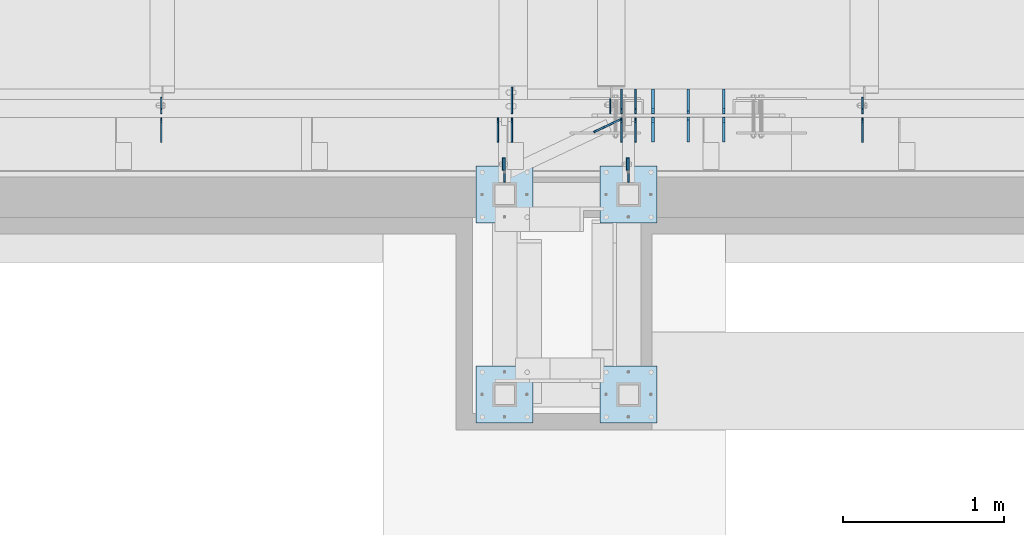
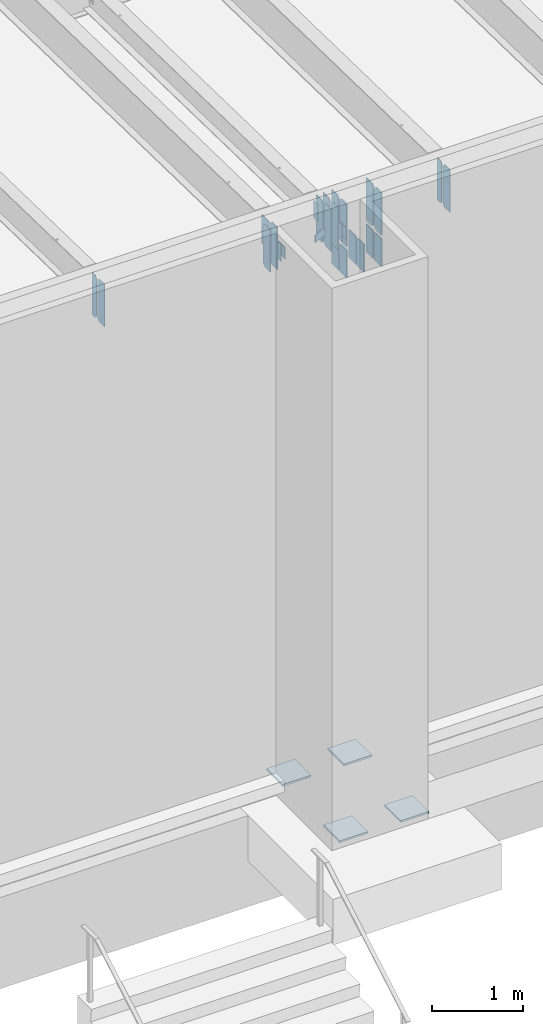
# One storey, part 1565 of 1763: 31 plates, 4 elements without a shape of their own.
"""IFC2X3 building model written with IfcOpenShell, lengths in millimetres."""

from ifc_helpers import new_model, si_unit, frame, origin_with_axes, place, context, subcontext, project, spatial, faceted_brep, material, type_object, element, aggregate, save


model = new_model("IFC2X3")

# Units and contexts
model_context = context("Model", 3, precision=1e-05, world=origin_with_axes())
body_context = subcontext(model_context, "Body", "Model", "MODEL_VIEW")
ifc_project = project(units=[si_unit("LENGTHUNIT", "METRE", prefix="MILLI"), si_unit("AREAUNIT", "SQUARE_METRE"), si_unit("VOLUMEUNIT", "CUBIC_METRE"), si_unit("MASSUNIT", "GRAM", prefix="KILO"), si_unit("TIMEUNIT", "SECOND"), si_unit("PLANEANGLEUNIT", "RADIAN"), si_unit("SOLIDANGLEUNIT", "STERADIAN"), si_unit("THERMODYNAMICTEMPERATUREUNIT", "DEGREE_CELSIUS"), si_unit("LUMINOUSINTENSITYUNIT", "LUMEN")], contexts=[model_context])

# Site, building, storey
site_placement = place(None, origin_with_axes())
site = spatial("IfcSite", under=ifc_project, at=site_placement, CompositionType="ELEMENT")
building_placement = place(site_placement, origin_with_axes())
building = spatial("IfcBuilding", under=site, at=building_placement, Name="Undefined", CompositionType="ELEMENT")
storey_placement = place(building_placement, origin_with_axes())
storey = spatial("IfcBuildingStorey", under=building, at=storey_placement, Name="Undefined", CompositionType="ELEMENT", Elevation=0.0)

# Assembly, plate
assembly_1_placement = place(storey_placement, origin_with_axes())
assembly_1 = element("IfcElementAssembly", 1, at=assembly_1_placement, inside=storey, Name="BEAM", AssemblyPlace="NOTDEFINED", PredefinedType="RIGID_FRAME")
ifc_material = material(Name="STEEL/A36")
plate_type_1 = type_object("IfcPlateType", PredefinedType="NOTDEFINED")
plate_1_placement = place(assembly_1_placement, frame((-29873.0120800854, -14055.7242553587, 11823.7), z_axis=(0.0, 0.0, 1.0), x_axis=(0.0, 1.0, 0.0)))
plate_1 = element("IfcPlate", 2, at=plate_1_placement, type_object=plate_type_1, material=ifc_material, Name="PLATE", context=body_context, shape_type="Brep", body=[
    faceted_brep([(0.0, -4.76249999999982, 0.0), (-2.83762346953154e-10, -4.7624999996915, 228.600006103516), (-2.83762346953154e-10, 4.76250000028813, 228.600006103517), (0.0, 4.76249999999982, 0.0), (76.1999969480166, -4.76249999961874, 228.600006103516), (76.1999969480166, 4.76250000036089, 228.600006103517), (76.1999969482931, -4.76249999991705, 0.0), (76.1999969482931, 4.76250000006257, 1.81898940354586e-12)], [[[0, 1, 2, 3]], [[1, 4, 5, 2]], [[4, 6, 7, 5]], [[6, 0, 3, 7]], [[5, 7, 3, 2]], [[6, 4, 1, 0]]]),
])
aggregate(assembly_1, [plate_1])

assembly_2_placement = place(storey_placement, origin_with_axes())
assembly_2 = element("IfcElementAssembly", 3, at=assembly_2_placement, inside=storey, Name="BEAM", AssemblyPlace="NOTDEFINED", PredefinedType="RIGID_FRAME")
plate_2_placement = place(assembly_2_placement, frame((-30644.5370800855, -14055.7242553587, 11823.7), z_axis=(0.0, 0.0, 1.0), x_axis=(0.0, 1.0, 0.0)))
plate_2 = element("IfcPlate", 4, at=plate_2_placement, type_object=plate_type_1, material=ifc_material, Name="PLATE", context=body_context, shape_type="Brep", body=[
    faceted_brep([(0.0, -4.76249999999982, 0.0), (-2.83762346953154e-10, -4.7624999996915, 228.600006103516), (-2.83762346953154e-10, 4.76250000028813, 228.600006103517), (0.0, 4.76249999999982, 0.0), (76.1999969480166, -4.76249999961874, 228.600006103516), (76.1999969480166, 4.76250000036089, 228.600006103517), (76.1999969482931, -4.76249999991705, 0.0), (76.1999969482931, 4.76250000006257, 1.81898940354586e-12)], [[[0, 1, 2, 3]], [[1, 4, 5, 2]], [[4, 6, 7, 5]], [[6, 0, 3, 7]], [[5, 7, 3, 2]], [[6, 4, 1, 0]]]),
])
aggregate(assembly_2, [plate_2])

# Assembly, plates
assembly_3_placement = place(storey_placement, origin_with_axes())
assembly_3 = element("IfcElementAssembly", 5, at=assembly_3_placement, inside=storey, Name="FRAME", AssemblyPlace="NOTDEFINED", PredefinedType="RIGID_FRAME")
plate_type_2 = type_object("IfcPlateType", PredefinedType="NOTDEFINED")
plate_3_placement = place(assembly_3_placement, frame((-29863.4870815854, -13979.5242583629, 12052.3000061035), z_axis=(0.0, 0.0, -1.0), x_axis=(0.0, -1.0, 0.0)))
plate_3 = element("IfcPlate", 6, at=plate_3_placement, type_object=plate_type_2, material=ifc_material, Name="PLATE", context=body_context, shape_type="Brep", body=[
    faceted_brep([(0.0, -4.76249999999982, 0.0), (-3.05175672110636e-06, -4.7625000002663, 152.399993896484), (-3.05175490211695e-06, 4.76249999972788, 152.399993896484), (0.0, 4.76249999999982, 0.0), (152.400009155272, -4.76249999975698, 152.399993896484), (152.400009155273, 4.76250000024447, 152.399993896484), (152.400009155272, -4.76249999948777, 5.45696821063757e-12), (152.400009155273, 4.76250000051368, 3.63797880709171e-12)], [[[0, 1, 2, 3]], [[1, 4, 5, 2]], [[4, 6, 7, 5]], [[6, 0, 3, 7]], [[5, 7, 3, 2]], [[6, 4, 1, 0]]]),
])
plate_4_placement = place(assembly_3_placement, frame((-30635.0120815855, -13979.5242583629, 12052.3000061035), z_axis=(0.0, 0.0, -1.0), x_axis=(0.0, -1.0, 0.0)))
plate_4 = element("IfcPlate", 7, at=plate_4_placement, type_object=plate_type_2, material=ifc_material, Name="PLATE", context=body_context, shape_type="Brep", body=[
    faceted_brep([(0.0, -4.76249999999982, 0.0), (-3.05175672110636e-06, -4.7625000002663, 152.399993896484), (-3.05175490211695e-06, 4.76249999972788, 152.399993896484), (0.0, 4.76249999999982, 0.0), (152.400009155272, -4.76249999975698, 152.399993896484), (152.400009155273, 4.76250000024447, 152.399993896484), (152.400009155272, -4.76249999948777, 5.45696821063757e-12), (152.400009155273, 4.76250000051368, 3.63797880709171e-12)], [[[0, 1, 2, 3]], [[1, 4, 5, 2]], [[4, 6, 7, 5]], [[6, 0, 3, 7]], [[5, 7, 3, 2]], [[6, 4, 1, 0]]]),
])

assembly_4_placement = place(storey_placement, origin_with_axes())
assembly_4 = element("IfcElementAssembly", 8, at=assembly_4_placement, inside=storey, Name="BEAM", AssemblyPlace="NOTDEFINED", PredefinedType="RIGID_FRAME")
plate_5_placement = place(assembly_4_placement, frame((-29819.0372734058, -13880.3060686171, 11590.3375), z_axis=(0.0, 0.0, 1.0), x_axis=(0.0, 1.0, 0.0)))
plate_5 = element("IfcPlate", 9, at=plate_5_placement, type_object=plate_type_2, material=ifc_material, Name="PLATE", context=body_context, shape_type="Brep", body=[
    faceted_brep([(0.0, -4.76249999999982, 0.0), (0.0, -4.76250000012806, 568.325012206604), (0.0, 4.7624999999025, 568.325012206606), (0.0, 4.76249999999982, 0.0), (120.649993896484, -4.76250000000073, 568.325012207031), (120.649993896484, 4.76250000000073, 568.325012207031), (152.399993896484, -4.76250000000073, 536.575012207031), (152.399993896484, 4.76250000000073, 536.575012207031), (152.399993896484, -4.76250000000073, 31.75), (152.399993896484, 4.76250000000073, 31.75), (120.650001525879, -4.76249999999709, 0.0), (120.650001525879, 4.76249999999709, 0.0)], [[[0, 1, 2, 3]], [[1, 4, 5, 2]], [[4, 6, 7, 5]], [[6, 8, 9, 7]], [[8, 10, 11, 9]], [[10, 0, 3, 11]], [[5, 7, 9, 11, 3, 2]], [[10, 8, 6, 4, 1, 0]]]),
])
plate_6_placement = place(assembly_4_placement, frame((-29906.3497734056, -13880.3060686171, 11590.3375), z_axis=(0.0, 0.0, 1.0), x_axis=(0.0, 1.0, 0.0)))
plate_6 = element("IfcPlate", 10, at=plate_6_placement, type_object=plate_type_2, material=ifc_material, Name="PLATE", context=body_context, shape_type="Brep", body=[
    faceted_brep([(0.0, -4.76249999999982, 0.0), (0.0, -4.76250000012806, 568.325012206604), (0.0, 4.7624999999025, 568.325012206606), (0.0, 4.76249999999982, 0.0), (120.649993896484, -4.76250000000073, 568.325012207031), (120.649993896484, 4.76250000000073, 568.325012207031), (152.399993896484, -4.76250000000073, 536.575012207031), (152.399993896484, 4.76250000000073, 536.575012207031), (152.399993896484, -4.76250000000073, 31.75), (152.399993896484, 4.76250000000073, 31.75), (120.650001525879, -4.76249999999709, 0.0), (120.650001525879, 4.76249999999709, 0.0)], [[[0, 1, 2, 3]], [[1, 4, 5, 2]], [[4, 6, 7, 5]], [[6, 8, 9, 7]], [[8, 10, 11, 9]], [[10, 0, 3, 11]], [[5, 7, 9, 11, 3, 2]], [[10, 8, 6, 4, 1, 0]]]),
])
plate_7_placement = place(assembly_4_placement, frame((-29819.0372734058, -13704.0935686171, 11590.3375), z_axis=(0.0, 0.0, 1.0), x_axis=(0.0, 1.0, 0.0)))
plate_7 = element("IfcPlate", 11, at=plate_7_placement, type_object=plate_type_2, material=ifc_material, Name="PLATE", context=body_context, shape_type="Brep", body=[
    faceted_brep([(0.0, -4.76250000000073, 31.75), (0.0, -4.76250000012078, 536.575012206626), (0.0, 4.76249999990978, 536.575012206629), (0.0, 4.76250000000073, 31.75), (31.75, -4.76250000012806, 568.325012206604), (31.75, 4.7624999999025, 568.325012206606), (152.399993896484, -4.76250000000073, 568.325012207031), (152.399993896484, 4.76250000000073, 568.325012207031), (152.400009155272, -4.76249999948777, 5.45696821063757e-12), (152.400009155273, 4.76250000051368, 3.63797880709171e-12), (31.75, -4.76250000000073, 0.0), (31.75, 4.76250000000073, 0.0)], [[[0, 1, 2, 3]], [[1, 4, 5, 2]], [[4, 6, 7, 5]], [[6, 8, 9, 7]], [[8, 10, 11, 9]], [[10, 0, 3, 11]], [[5, 7, 9, 11, 3, 2]], [[10, 8, 6, 4, 1, 0]]]),
])
plate_8_placement = place(assembly_4_placement, frame((-29906.3497734056, -13704.0935686171, 11590.3375), z_axis=(0.0, 0.0, 1.0), x_axis=(0.0, 1.0, 0.0)))
plate_8 = element("IfcPlate", 12, at=plate_8_placement, type_object=plate_type_2, material=ifc_material, Name="PLATE", context=body_context, shape_type="Brep", body=[
    faceted_brep([(0.0, -4.76250000000073, 31.75), (0.0, -4.76250000012078, 536.575012206626), (0.0, 4.76249999990978, 536.575012206629), (0.0, 4.76250000000073, 31.75), (31.75, -4.76250000012806, 568.325012206604), (31.75, 4.7624999999025, 568.325012206606), (152.399993896484, -4.76250000000073, 568.325012207031), (152.399993896484, 4.76250000000073, 568.325012207031), (152.400009155272, -4.76249999948777, 5.45696821063757e-12), (152.400009155273, 4.76250000051368, 3.63797880709171e-12), (31.75, -4.76250000000073, 0.0), (31.75, 4.76250000000073, 0.0)], [[[0, 1, 2, 3]], [[1, 4, 5, 2]], [[4, 6, 7, 5]], [[6, 8, 9, 7]], [[8, 10, 11, 9]], [[10, 0, 3, 11]], [[5, 7, 9, 11, 3, 2]], [[10, 8, 6, 4, 1, 0]]]),
])
plate_9_placement = place(assembly_4_placement, frame((-30590.5625339122, -13880.3060686171, 11590.3375), z_axis=(0.0, 0.0, 1.0), x_axis=(0.0, 1.0, 0.0)))
plate_9 = element("IfcPlate", 13, at=plate_9_placement, type_object=plate_type_2, material=ifc_material, Name="PLATE", context=body_context, shape_type="Brep", body=[
    faceted_brep([(0.0, -4.76249999999982, 0.0), (0.0, -4.76250000012806, 568.325012206604), (0.0, 4.7624999999025, 568.325012206606), (0.0, 4.76249999999982, 0.0), (120.649993896484, -4.76250000000073, 568.325012207031), (120.649993896484, 4.76250000000073, 568.325012207031), (152.399993896484, -4.76250000000073, 536.575012207031), (152.399993896484, 4.76250000000073, 536.575012207031), (152.399993896484, -4.76250000000073, 31.75), (152.399993896484, 4.76250000000073, 31.75), (120.650001525879, -4.76249999999709, 0.0), (120.650001525879, 4.76249999999709, 0.0)], [[[0, 1, 2, 3]], [[1, 4, 5, 2]], [[4, 6, 7, 5]], [[6, 8, 9, 7]], [[8, 10, 11, 9]], [[10, 0, 3, 11]], [[5, 7, 9, 11, 3, 2]], [[10, 8, 6, 4, 1, 0]]]),
])
plate_10_placement = place(assembly_4_placement, frame((-30677.875033912, -13880.3060686171, 11590.3375), z_axis=(0.0, 0.0, 1.0), x_axis=(0.0, 1.0, 0.0)))
plate_10 = element("IfcPlate", 14, at=plate_10_placement, type_object=plate_type_2, material=ifc_material, Name="PLATE", context=body_context, shape_type="Brep", body=[
    faceted_brep([(0.0, -4.76249999999982, 0.0), (0.0, -4.76250000012806, 568.325012206604), (0.0, 4.7624999999025, 568.325012206606), (0.0, 4.76249999999982, 0.0), (120.649993896484, -4.76250000000073, 568.325012207031), (120.649993896484, 4.76250000000073, 568.325012207031), (152.399993896484, -4.76250000000073, 536.575012207031), (152.399993896484, 4.76250000000073, 536.575012207031), (152.399993896484, -4.76250000000073, 31.75), (152.399993896484, 4.76250000000073, 31.75), (120.650001525879, -4.76249999999709, 0.0), (120.650001525879, 4.76249999999709, 0.0)], [[[0, 1, 2, 3]], [[1, 4, 5, 2]], [[4, 6, 7, 5]], [[6, 8, 9, 7]], [[8, 10, 11, 9]], [[10, 0, 3, 11]], [[5, 7, 9, 11, 3, 2]], [[10, 8, 6, 4, 1, 0]]]),
])
plate_type_3 = type_object("IfcPlateType", PredefinedType="NOTDEFINED")
plate_11_placement = place(assembly_4_placement, frame((-32773.3757737632, -13704.0935686171, 11590.3375), z_axis=(0.0, 0.0, 1.0), x_axis=(0.0, 1.0, 0.0)))
plate_11 = element("IfcPlate", 15, at=plate_11_placement, type_object=plate_type_3, material=ifc_material, Name="PLATE", context=body_context, shape_type="Brep", body=[
    faceted_brep([(0.0, -3.96899999999732, 31.75), (0.0, -3.96899999999732, 538.162475585938), (0.0, 3.96899999999732, 538.162475585938), (0.0, 3.96899999999732, 31.75), (31.75, -3.96899999999732, 569.912475585938), (31.75, 3.96899999999732, 569.912475585938), (101.599998474121, -3.96899999999732, 569.912475585938), (101.599998474121, 3.96899999999732, 569.912475585938), (101.599998474121, -3.96899999999732, 0.0), (101.599998474121, 3.96899999999732, 0.0), (31.75, -3.96899999999732, 0.0), (31.75, 3.96899999999732, 0.0)], [[[0, 1, 2, 3]], [[1, 4, 5, 2]], [[4, 6, 7, 5]], [[6, 8, 9, 7]], [[8, 10, 11, 9]], [[10, 0, 3, 11]], [[5, 7, 9, 11, 3, 2]], [[10, 8, 6, 4, 1, 0]]]),
])

# Plate
plate_type_4 = type_object("IfcPlateType", PredefinedType="NOTDEFINED")
plate_12_placement = place(assembly_3_placement, frame((-30041.2870783858, -14030.3242675181, 5079.99999999999), z_axis=(1.0, 0.0, 0.0), x_axis=(0.0, -1.0, 0.0)))
plate_12 = element("IfcPlate", 16, at=plate_12_placement, type_object=plate_type_4, material=ifc_material, Name="PLATE", context=body_context, shape_type="Brep", body=[
    faceted_brep([(0.0, -12.6999999999971, -1.81898940354586e-12), (0.0, -12.6999999999998, 355.600006103516), (0.0, 12.6999999999998, 355.600006103516), (0.0, 12.6999999999971, -1.81898940354586e-12), (355.600006103516, -12.6999999999998, 355.600006103516), (355.600006103516, 12.6999999999998, 355.600006103516), (355.600006103516, -12.6999999999998, 0.0), (355.600006103516, 12.6999999999998, 0.0)], [[[0, 1, 2, 3]], [[1, 4, 5, 2]], [[4, 6, 7, 5]], [[6, 0, 3, 7]], [[5, 7, 3, 2]], [[6, 4, 1, 0]]]),
])

plate_13_placement = place(assembly_3_placement, frame((-30812.8122736983, -14030.3242675181, 5080.0), z_axis=(1.0, 0.0, 0.0), x_axis=(0.0, -1.0, 0.0)))
plate_13 = element("IfcPlate", 17, at=plate_13_placement, type_object=plate_type_4, material=ifc_material, Name="PLATE", context=body_context, shape_type="Brep", body=[
    faceted_brep([(0.0, -12.6999999999971, -1.81898940354586e-12), (0.0, -12.6999999999998, 355.600006103516), (0.0, 12.6999999999998, 355.600006103516), (0.0, 12.6999999999971, -1.81898940354586e-12), (355.600006103516, -12.6999999999998, 355.600006103516), (355.600006103516, 12.6999999999998, 355.600006103516), (355.600006103516, -12.6999999999998, 0.0), (355.600006103516, 12.6999999999998, 0.0)], [[[0, 1, 2, 3]], [[1, 4, 5, 2]], [[4, 6, 7, 5]], [[6, 0, 3, 7]], [[5, 7, 3, 2]], [[6, 4, 1, 0]]]),
])

plate_14_placement = place(assembly_3_placement, frame((-30041.2870783858, -15274.9242675181, 5080.0), z_axis=(1.0, 0.0, 0.0), x_axis=(0.0, -1.0, 0.0)))
plate_14 = element("IfcPlate", 18, at=plate_14_placement, type_object=plate_type_4, material=ifc_material, Name="PLATE", context=body_context, shape_type="Brep", body=[
    faceted_brep([(0.0, -12.6999999999971, -1.81898940354586e-12), (0.0, -12.6999999999998, 355.600006103516), (0.0, 12.6999999999998, 355.600006103516), (0.0, 12.6999999999971, -1.81898940354586e-12), (355.600006103516, -12.6999999999998, 355.600006103516), (355.600006103516, 12.6999999999998, 355.600006103516), (355.600006103516, -12.6999999999998, 0.0), (355.600006103516, 12.6999999999998, 0.0)], [[[0, 1, 2, 3]], [[1, 4, 5, 2]], [[4, 6, 7, 5]], [[6, 0, 3, 7]], [[5, 7, 3, 2]], [[6, 4, 1, 0]]]),
])

plate_15_placement = place(assembly_3_placement, frame((-30812.8122736983, -15274.9242675181, 5080.0), z_axis=(1.0, 0.0, 0.0), x_axis=(0.0, -1.0, 0.0)))
plate_15 = element("IfcPlate", 19, at=plate_15_placement, type_object=plate_type_4, material=ifc_material, Name="PLATE", context=body_context, shape_type="Brep", body=[
    faceted_brep([(0.0, -12.6999999999971, -1.81898940354586e-12), (0.0, -12.6999999999998, 355.600006103516), (0.0, 12.6999999999998, 355.600006103516), (0.0, 12.6999999999971, -1.81898940354586e-12), (355.600006103516, -12.6999999999998, 355.600006103516), (355.600006103516, 12.6999999999998, 355.600006103516), (355.600006103516, -12.6999999999998, 0.0), (355.600006103516, 12.6999999999998, 0.0)], [[[0, 1, 2, 3]], [[1, 4, 5, 2]], [[4, 6, 7, 5]], [[6, 0, 3, 7]], [[5, 7, 3, 2]], [[6, 4, 1, 0]]]),
])

aggregate(assembly_3, [plate_3, plate_4, plate_12, plate_13, plate_14, plate_15])

plate_type_5 = type_object("IfcPlateType", PredefinedType="NOTDEFINED")
plate_16_placement = place(assembly_4_placement, frame((-30080.0829164731, -13818.4860869766, 11734.8), z_axis=(0.0, 0.0, 1.0), x_axis=(0.90394142994217, 0.427656276972646, 0.0)))
plate_16 = element("IfcPlate", 20, at=plate_16_placement, type_object=plate_type_5, material=ifc_material, Name="PLATE", context=body_context, shape_type="Brep", body=[
    faceted_brep([(0.0, -4.76249999999982, 0.0), (1.45519152283669e-11, -4.76250000000448, 101.60001373291), (0.0, 4.76250000000243, 101.60001373291), (0.0, 4.76249999999982, 0.0), (184.672088622705, -4.76249999999175, 101.60001373291), (184.67208862269, 4.76250000001153, 101.60001373291), (184.672088622705, -4.76249999999175, 0.0), (184.67208862269, 4.76250000001153, 0.0)], [[[0, 1, 2, 3]], [[1, 4, 5, 2]], [[4, 6, 7, 5]], [[6, 0, 3, 7]], [[5, 7, 3, 2]], [[6, 4, 1, 0]]]),
])

plate_17_placement = place(assembly_4_placement, frame((-28406.1627736144, -13704.0935686171, 11590.3375), z_axis=(0.0, 0.0, 1.0), x_axis=(0.0, 1.0, 0.0)))
plate_17 = element("IfcPlate", 21, at=plate_17_placement, type_object=plate_type_5, material=ifc_material, Name="PLATE", context=body_context, shape_type="Brep", body=[
    faceted_brep([(0.0, -4.76250000000073, 31.75), (0.0, -4.76250000000073, 538.162475585938), (0.0, 4.76250000000073, 538.162475585938), (0.0, 4.76250000000073, 31.75), (31.75, -4.76250000000073, 569.912475585938), (31.75, 4.76250000000073, 569.912475585938), (101.599998474121, -4.76250000000073, 569.912475585938), (101.599998474121, 4.76250000000073, 569.912475585938), (101.599990844727, -4.76250000000073, 0.0), (101.599990844727, 4.76250000000073, 0.0), (31.75, -4.76250000000073, 0.0), (31.75, 4.76250000000073, 0.0)], [[[0, 1, 2, 3]], [[1, 4, 5, 2]], [[4, 6, 7, 5]], [[6, 8, 9, 7]], [[8, 10, 11, 9]], [[10, 0, 3, 11]], [[5, 7, 9, 11, 3, 2]], [[10, 8, 6, 4, 1, 0]]]),
])

plate_type_6 = type_object("IfcPlateType", PredefinedType="NOTDEFINED")
plate_18_placement = place(assembly_4_placement, frame((-29977.7872736983, -13704.0935686171, 12141.3913344018), z_axis=(0.0, 1.0, 0.0), x_axis=(0.0, 0.0, -1.0)))
plate_18 = element("IfcPlate", 22, at=plate_18_placement, type_object=plate_type_6, material=ifc_material, Name="PLATE", context=body_context, shape_type="Brep", body=[
    faceted_brep([(1.81898940354586e-12, -3.17500000000291, 0.0), (0.0, -3.17499999999927, 93.6624984741211), (0.0, 3.17499999999927, 93.6624984741211), (-1.81898940354586e-12, 3.17499999997381, 0.0), (228.600006103516, -3.17499999999927, 93.6624984741211), (228.600006103516, 3.17499999999927, 93.6624984741211), (228.600006103516, -3.17500000001019, -7.27595761418343e-12), (228.600006103516, 3.17499999999563, -7.27595761418343e-12)], [[[0, 1, 2, 3]], [[1, 4, 5, 2]], [[4, 6, 7, 5]], [[6, 0, 3, 7]], [[5, 7, 3, 2]], [[6, 4, 1, 0]]]),
])

plate_type_7 = type_object("IfcPlateType", PredefinedType="NOTDEFINED")
plate_19_placement = place(assembly_4_placement, frame((-29711.4508194717, -13880.3060686171, 11590.3375), z_axis=(0.0, 0.0, 1.0), x_axis=(0.0, 1.0, 0.0)))
plate_19 = element("IfcPlate", 23, at=plate_19_placement, type_object=plate_type_7, material=ifc_material, Name="PLATE", context=body_context, shape_type="Brep", body=[
    faceted_brep([(-7.27595761418343e-12, -7.9375, 0.0), (0.0, -7.9375, 568.325012207031), (0.0, 7.9375, 568.325012207031), (-7.27595761418343e-12, 7.9375, 0.0), (120.649993896484, -7.9375, 568.325012207031), (120.649993896484, 7.9375, 568.325012207031), (152.399993896484, -7.9375, 536.575012207031), (152.399993896484, 7.9375, 536.575012207031), (152.399993896484, -7.9375, 31.75), (152.399993896484, 7.9375, 31.75), (120.649993896484, -7.9375, 0.0), (120.649993896484, 7.9375, 0.0)], [[[0, 1, 2, 3]], [[1, 4, 5, 2]], [[4, 6, 7, 5]], [[6, 8, 9, 7]], [[8, 10, 11, 9]], [[10, 0, 3, 11]], [[5, 7, 9, 11, 3, 2]], [[10, 8, 6, 4, 1, 0]]]),
])

plate_20_placement = place(assembly_4_placement, frame((-29711.4508194717, -13704.0935686171, 11590.3375), z_axis=(0.0, 0.0, 1.0), x_axis=(0.0, 1.0, 0.0)))
plate_20 = element("IfcPlate", 24, at=plate_20_placement, type_object=plate_type_7, material=ifc_material, Name="PLATE", context=body_context, shape_type="Brep", body=[
    faceted_brep([(0.0, -7.9375, 31.75), (0.0, -7.9375, 536.575012207031), (0.0, 7.9375, 536.575012207031), (0.0, 7.9375, 31.75), (31.75, -7.9375, 568.325012207031), (31.75, 7.9375, 568.325012207031), (152.399993896484, -7.9375, 568.325012207031), (152.399993896484, 7.9375, 568.325012207031), (152.399993896484, -7.9375, -1.81898940354586e-12), (152.399993896484, 7.9375, -1.81898940354586e-12), (31.75, -7.9375, 0.0), (31.75, 7.9375, 0.0)], [[[0, 1, 2, 3]], [[1, 4, 5, 2]], [[4, 6, 7, 5]], [[6, 8, 9, 7]], [[8, 10, 11, 9]], [[10, 0, 3, 11]], [[5, 7, 9, 11, 3, 2]], [[10, 8, 6, 4, 1, 0]]]),
])

plate_21_placement = place(assembly_4_placement, frame((-29270.9470879434, -13880.3060686171, 11590.3375), z_axis=(0.0, 0.0, 1.0), x_axis=(0.0, 1.0, 0.0)))
plate_21 = element("IfcPlate", 25, at=plate_21_placement, type_object=plate_type_7, material=ifc_material, Name="PLATE", context=body_context, shape_type="Brep", body=[
    faceted_brep([(-7.27595761418343e-12, -7.9375, 0.0), (0.0, -7.9375, 568.325012207031), (0.0, 7.9375, 568.325012207031), (-7.27595761418343e-12, 7.9375, 0.0), (120.649993896484, -7.9375, 568.325012207031), (120.649993896484, 7.9375, 568.325012207031), (152.399993896484, -7.9375, 536.575012207031), (152.399993896484, 7.9375, 536.575012207031), (152.399993896484, -7.9375, 31.75), (152.399993896484, 7.9375, 31.75), (120.649993896484, -7.9375, 0.0), (120.649993896484, 7.9375, 0.0)], [[[0, 1, 2, 3]], [[1, 4, 5, 2]], [[4, 6, 7, 5]], [[6, 8, 9, 7]], [[8, 10, 11, 9]], [[10, 0, 3, 11]], [[5, 7, 9, 11, 3, 2]], [[10, 8, 6, 4, 1, 0]]]),
])

plate_22_placement = place(assembly_4_placement, frame((-29270.9470879434, -13704.0935686171, 11590.3375), z_axis=(0.0, 0.0, 1.0), x_axis=(0.0, 1.0, 0.0)))
plate_22 = element("IfcPlate", 26, at=plate_22_placement, type_object=plate_type_7, material=ifc_material, Name="PLATE", context=body_context, shape_type="Brep", body=[
    faceted_brep([(0.0, -7.9375, 31.75), (0.0, -7.9375, 536.575012207031), (0.0, 7.9375, 536.575012207031), (0.0, 7.9375, 31.75), (31.75, -7.9375, 568.325012207031), (31.75, 7.9375, 568.325012207031), (152.399993896484, -7.9375, 568.325012207031), (152.399993896484, 7.9375, 568.325012207031), (152.399993896484, -7.9375, -1.81898940354586e-12), (152.399993896484, 7.9375, -1.81898940354586e-12), (31.75, -7.9375, 0.0), (31.75, 7.9375, 0.0)], [[[0, 1, 2, 3]], [[1, 4, 5, 2]], [[4, 6, 7, 5]], [[6, 8, 9, 7]], [[8, 10, 11, 9]], [[10, 0, 3, 11]], [[5, 7, 9, 11, 3, 2]], [[10, 8, 6, 4, 1, 0]]]),
])

plate_type_8 = type_object("IfcPlateType", PredefinedType="NOTDEFINED")
plate_23_placement = place(assembly_4_placement, frame((-32773.3757737632, -13727.9060686171, 11588.75), z_axis=(0.0, 0.0, 1.0), x_axis=(0.0, -1.0, 0.0)))
plate_23 = element("IfcPlate", 27, at=plate_23_placement, type_object=plate_type_8, material=ifc_material, Name="PLATE", context=body_context, shape_type="Brep", body=[
    faceted_brep([(0.0, -3.96899999999732, 31.75), (0.0, -3.96899999999732, 539.75), (0.0, 3.96899999999732, 539.75), (0.0, 3.96899999999732, 31.75), (31.75, -3.96899999999732, 571.5), (31.75, 3.96899999999732, 571.5), (154.78125, -3.96899999999732, 571.5), (154.78125, 3.96899999999732, 571.5), (154.78125, -3.96899999999732, 0.0), (154.78125, 3.96899999999732, 0.0), (31.75, -3.96899999999732, 0.0), (31.75, 3.96899999999732, 0.0)], [[[0, 1, 2, 3]], [[1, 4, 5, 2]], [[4, 6, 7, 5]], [[6, 8, 9, 7]], [[8, 10, 11, 9]], [[10, 0, 3, 11]], [[5, 7, 9, 11, 3, 2]], [[10, 8, 6, 4, 1, 0]]]),
])

plate_type_9 = type_object("IfcPlateType", PredefinedType="NOTDEFINED")
plate_24_placement = place(assembly_4_placement, frame((-29270.9470879434, -13725.5250000064, 11544.2999999991), z_axis=(0.0, 0.0, -1.0), x_axis=(0.0, -1.0, 0.0)))
plate_24 = element("IfcPlate", 28, at=plate_24_placement, type_object=plate_type_9, material=ifc_material, Name="PLATE", context=body_context, shape_type="Brep", body=[
    faceted_brep([(-3.27418092638254e-10, -7.9375, 19.0499992370605), (-6.41739461570978e-09, -7.9375, 372.360992431641), (-6.41739461570978e-09, 7.9375, 372.360992431641), (-3.27418092638254e-10, 7.9375, 19.0499992370605), (154.781066894531, -7.9375, 372.360992431641), (154.781066894531, 7.9375, 372.360992431641), (154.781066894531, -7.9375, 1.81898940354586e-11), (154.781066894531, 7.9375, 1.81898940354586e-11), (19.0499815529183, -7.9375, 0.0), (19.0499815529183, 7.9375, 0.0)], [[[0, 1, 2, 3]], [[1, 4, 5, 2]], [[4, 6, 7, 5]], [[6, 8, 9, 7]], [[8, 0, 3, 9]], [[5, 7, 9, 3, 2]], [[8, 6, 4, 1, 0]]]),
])

plate_25_placement = place(assembly_4_placement, frame((-29711.4508194717, -13725.5250000066, 11544.3000002962), z_axis=(0.0, 0.0, -1.0), x_axis=(0.0, -1.0, 0.0)))
plate_25 = element("IfcPlate", 29, at=plate_25_placement, type_object=plate_type_9, material=ifc_material, Name="PLATE", context=body_context, shape_type="Brep", body=[
    faceted_brep([(-3.27418092638254e-10, -7.9375, 19.0499992370605), (-6.41739461570978e-09, -7.9375, 372.360992431641), (-6.41739461570978e-09, 7.9375, 372.360992431641), (-3.27418092638254e-10, 7.9375, 19.0499992370605), (154.781066894531, -7.9375, 372.360992431641), (154.781066894531, 7.9375, 372.360992431641), (154.781066894531, -7.9375, 1.81898940354586e-11), (154.781066894531, 7.9375, 1.81898940354586e-11), (19.0499815529183, -7.9375, 0.0), (19.0499815529183, 7.9375, 0.0)], [[[0, 1, 2, 3]], [[1, 4, 5, 2]], [[4, 6, 7, 5]], [[6, 8, 9, 7]], [[8, 0, 3, 9]], [[5, 7, 9, 3, 2]], [[8, 6, 4, 1, 0]]]),
])

plate_26_placement = place(assembly_4_placement, frame((-29491.1989537075, -13725.5250000068, 11544.2999976467), z_axis=(0.0, 0.0, -1.0), x_axis=(0.0, -1.0, 0.0)))
plate_26 = element("IfcPlate", 30, at=plate_26_placement, type_object=plate_type_9, material=ifc_material, Name="PLATE", context=body_context, shape_type="Brep", body=[
    faceted_brep([(-3.27418092638254e-10, -7.9375, 19.0499992370605), (-6.41739461570978e-09, -7.9375, 372.360992431641), (-6.41739461570978e-09, 7.9375, 372.360992431641), (-3.27418092638254e-10, 7.9375, 19.0499992370605), (154.781066894531, -7.9375, 372.360992431641), (154.781066894531, 7.9375, 372.360992431641), (154.781066894531, -7.9375, 1.81898940354586e-11), (154.781066894531, 7.9375, 1.81898940354586e-11), (19.0499815529183, -7.9375, 0.0), (19.0499815529183, 7.9375, 0.0)], [[[0, 1, 2, 3]], [[1, 4, 5, 2]], [[4, 6, 7, 5]], [[6, 8, 9, 7]], [[8, 0, 3, 9]], [[5, 7, 9, 3, 2]], [[8, 6, 4, 1, 0]]]),
])

plate_type_10 = type_object("IfcPlateType", PredefinedType="NOTDEFINED")
plate_27_placement = place(assembly_4_placement, frame((-29270.9470879404, -13551.6935747206, 11544.3000000744), z_axis=(0.0, 0.0, -1.0), x_axis=(0.0, -1.0, 0.0)))
plate_27 = element("IfcPlate", 31, at=plate_27_placement, type_object=plate_type_10, material=ifc_material, Name="PLATE", context=body_context, shape_type="Brep", body=[
    faceted_brep([(-7.27595761418343e-12, -7.9375, 0.0), (-6.41739461570978e-09, -7.9375, 372.360992431641), (-6.41739461570978e-09, 7.9375, 372.360992431641), (-7.27595761418343e-12, 7.9375, 0.0), (154.78141784668, -7.9375, 372.360992431641), (154.78141784668, 7.9375, 372.360992431641), (154.78141784668, -7.9375, 19.0499992370624), (154.78141784668, 7.9375, 19.0499992370624), (135.731418609619, -7.9375, 1.81898940354586e-12), (135.731418609619, 7.9375, 1.81898940354586e-12)], [[[0, 1, 2, 3]], [[1, 4, 5, 2]], [[4, 6, 7, 5]], [[6, 8, 9, 7]], [[8, 0, 3, 9]], [[5, 7, 9, 3, 2]], [[8, 6, 4, 1, 0]]]),
])

plate_28_placement = place(assembly_4_placement, frame((-29711.4508194717, -13551.6935747205, 11544.3000002962), z_axis=(0.0, 0.0, -1.0), x_axis=(0.0, -1.0, 0.0)))
plate_28 = element("IfcPlate", 32, at=plate_28_placement, type_object=plate_type_10, material=ifc_material, Name="PLATE", context=body_context, shape_type="Brep", body=[
    faceted_brep([(-7.27595761418343e-12, -7.9375, 0.0), (-6.41739461570978e-09, -7.9375, 372.360992431641), (-6.41739461570978e-09, 7.9375, 372.360992431641), (-7.27595761418343e-12, 7.9375, 0.0), (154.78141784668, -7.9375, 372.360992431641), (154.78141784668, 7.9375, 372.360992431641), (154.78141784668, -7.9375, 19.0499992370624), (154.78141784668, 7.9375, 19.0499992370624), (135.731418609619, -7.9375, 1.81898940354586e-12), (135.731418609619, 7.9375, 1.81898940354586e-12)], [[[0, 1, 2, 3]], [[1, 4, 5, 2]], [[4, 6, 7, 5]], [[6, 8, 9, 7]], [[8, 0, 3, 9]], [[5, 7, 9, 3, 2]], [[8, 6, 4, 1, 0]]]),
])

plate_29_placement = place(assembly_4_placement, frame((-29491.1989537075, -13551.6935747208, 11544.2999976467), z_axis=(0.0, 0.0, -1.0), x_axis=(0.0, -1.0, 0.0)))
plate_29 = element("IfcPlate", 33, at=plate_29_placement, type_object=plate_type_10, material=ifc_material, Name="PLATE", context=body_context, shape_type="Brep", body=[
    faceted_brep([(-7.27595761418343e-12, -7.9375, 0.0), (-6.41739461570978e-09, -7.9375, 372.360992431641), (-6.41739461570978e-09, 7.9375, 372.360992431641), (-7.27595761418343e-12, 7.9375, 0.0), (154.78141784668, -7.9375, 372.360992431641), (154.78141784668, 7.9375, 372.360992431641), (154.78141784668, -7.9375, 19.0499992370624), (154.78141784668, 7.9375, 19.0499992370624), (135.731418609619, -7.9375, 1.81898940354586e-12), (135.731418609619, 7.9375, 1.81898940354586e-12)], [[[0, 1, 2, 3]], [[1, 4, 5, 2]], [[4, 6, 7, 5]], [[6, 8, 9, 7]], [[8, 0, 3, 9]], [[5, 7, 9, 3, 2]], [[8, 6, 4, 1, 0]]]),
])

plate_type_11 = type_object("IfcPlateType", PredefinedType="NOTDEFINED")
plate_30_placement = place(assembly_4_placement, frame((-30590.5622736983, -13704.0935686171, 12127.1640902963), z_axis=(0.0, 1.0, 0.0), x_axis=(0.0, 0.0, -1.0)))
plate_30 = element("IfcPlate", 34, at=plate_30_placement, type_object=plate_type_11, material=ifc_material, Name="PLATE", context=body_context, shape_type="Brep", body=[
    faceted_brep([(0.0, -4.76249999999982, 0.0), (0.0, -4.76250000000073, 165.100006103516), (0.0, 4.76250000000073, 165.100006103516), (0.0, 4.76249999999982, 0.0), (381.0, -4.76250000000073, 165.100006103516), (381.0, 4.76250000000073, 165.100006103516), (381.0, -4.76250000000073, 0.0), (381.0, 4.76250000000073, 0.0)], [[[0, 1, 2, 3]], [[1, 4, 5, 2]], [[4, 6, 7, 5]], [[6, 0, 3, 7]], [[5, 7, 3, 2]], [[6, 4, 1, 0]]]),
])

plate_type_12 = type_object("IfcPlateType", PredefinedType="NOTDEFINED")
plate_31_placement = place(assembly_4_placement, frame((-28406.1627736144, -13727.9060686171, 11588.75), z_axis=(0.0, 0.0, 1.0), x_axis=(0.0, -1.0, 0.0)))
plate_31 = element("IfcPlate", 35, at=plate_31_placement, type_object=plate_type_12, material=ifc_material, Name="PLATE", context=body_context, shape_type="Brep", body=[
    faceted_brep([(0.0, -4.76250000000073, 31.75), (0.0, -4.76250000000073, 539.75), (0.0, 4.76250000000073, 539.75), (0.0, 4.76250000000073, 31.75), (31.75, -4.76250000000073, 571.5), (31.75, 4.76250000000073, 571.5), (154.78125, -4.76250000000073, 571.5), (154.78125, 4.76250000000073, 571.5), (154.78125, -4.76250000000073, 0.0), (154.78125, 4.76250000000073, 0.0), (31.75, -4.76250000000073, 0.0), (31.75, 4.76250000000073, 0.0)], [[[0, 1, 2, 3]], [[1, 4, 5, 2]], [[4, 6, 7, 5]], [[6, 8, 9, 7]], [[8, 10, 11, 9]], [[10, 0, 3, 11]], [[5, 7, 9, 11, 3, 2]], [[10, 8, 6, 4, 1, 0]]]),
])

aggregate(assembly_4, [plate_16, plate_18, plate_5, plate_6, plate_7, plate_8, plate_9, plate_10, plate_19, plate_20, plate_21, plate_22, plate_23, plate_24, plate_27, plate_25, plate_26, plate_28, plate_29, plate_30, plate_31, plate_17, plate_11])

save(model, "model.ifc")
